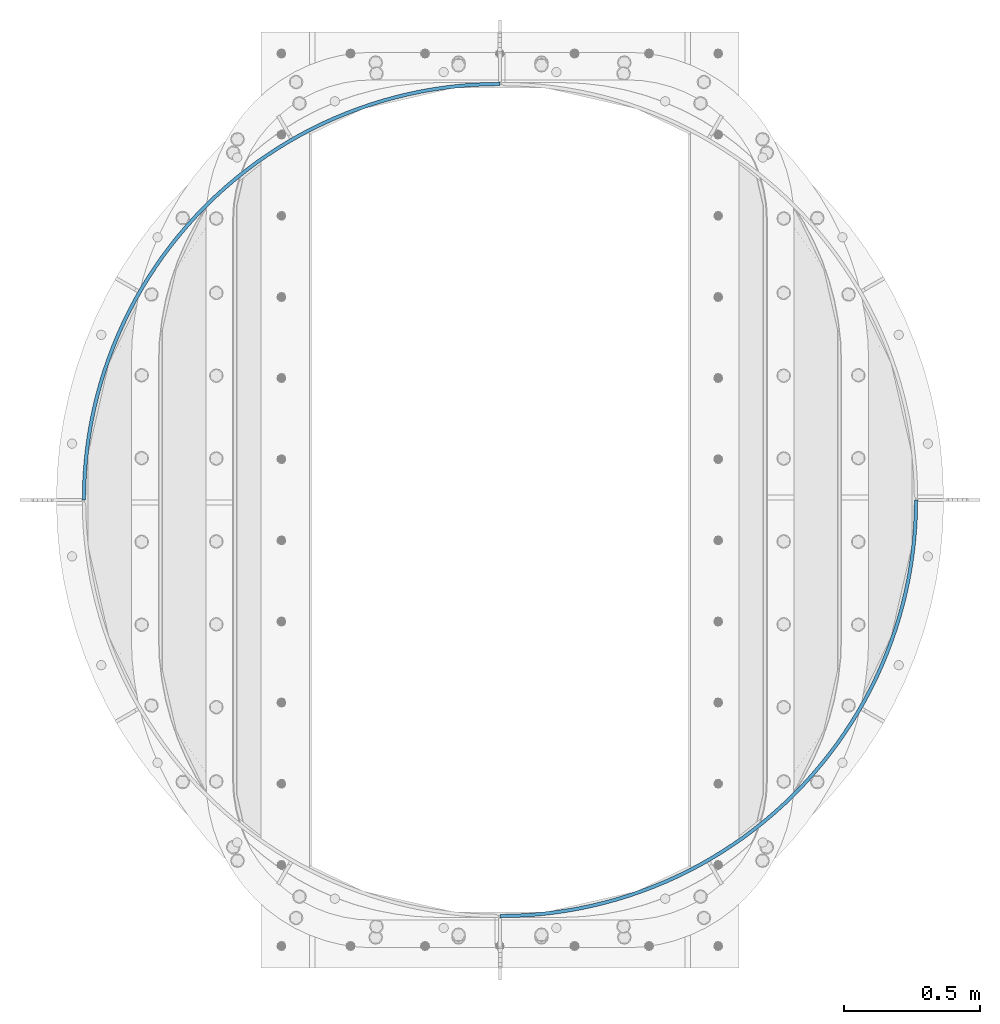
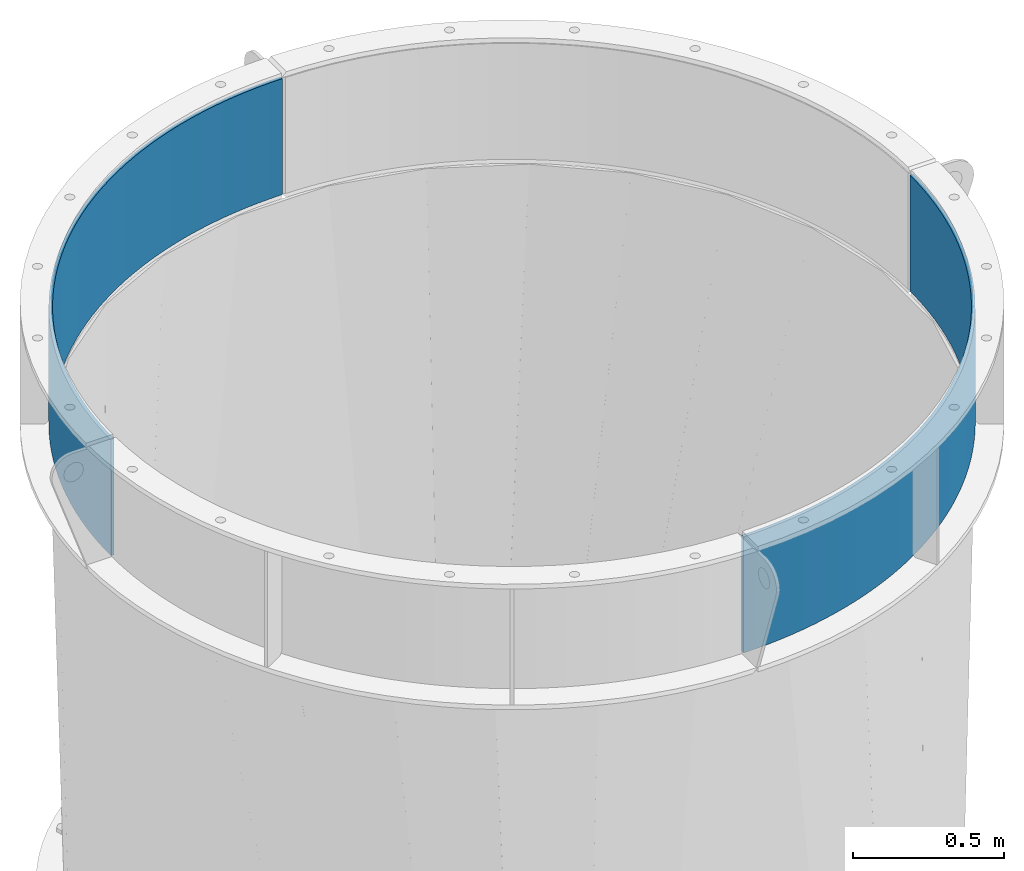
# One storey, part 8 of 15: 2 beams, 1 element without a shape of its own.
"""IFC2X3 building model written with IfcOpenShell, lengths in millimetres."""

import ifcopenshell
import ifcopenshell.guid

model = None  # the IFC model being written
_history = None  # IfcOwnerHistory: only IFC2X3 demands one
_inside = {}  # id of a spatial element -> (the spatial element, [elements in it])
_under = {}  # id of a project, library or spatial element -> (it, [spatial elements below it])
_declared = {}  # id of a project -> (the project, [libraries it declares])
_typed = {}  # id of a type object -> (the type object, [elements of that type])
_made_of = {}  # id of a material, layer set ... -> (it, [elements and type objects made of it])


def new_model(schema):
    """Start an empty IFC model of exactly this schema.

    Asked for "IFC4X3", IfcOpenShell would pick the latest addendum, in which some entities
    have other attributes; the version numbers below select the first issue.
    IFC2X3 requires an IfcOwnerHistory on every rooted entity: one is made here for all.
    """
    global model, _history
    if schema == "IFC4X3":
        model = ifcopenshell.file(schema_version=(4, 3, 0, 0))
    else:
        model = ifcopenshell.file(schema=schema)
    _inside.clear()
    _under.clear()
    _declared.clear()
    _typed.clear()
    _made_of.clear()
    _history = None
    if model.schema == "IFC2X3":
        org = make("IfcOrganization", Name="unknown")
        user = make(
            "IfcPersonAndOrganization",
            ThePerson=make("IfcPerson", FamilyName="unknown"),
            TheOrganization=org,
        )
        app = make(
            "IfcApplication",
            ApplicationDeveloper=org,
            Version="unknown",
            ApplicationFullName="unknown",
            ApplicationIdentifier="unknown",
        )
        _history = make(
            "IfcOwnerHistory",
            OwningUser=user,
            OwningApplication=app,
            ChangeAction="ADDED",
            CreationDate=0,
        )
    return model


def make(cls, **values):
    """One entity of the class cls with the attributes given. An attribute that is None is left unset."""
    return model.create_entity(
        cls, **{name: value for name, value in values.items() if value is not None}
    )


def rooted(cls, **values):
    """An entity with a GlobalId (a new one), such as an element, a storey or a relation."""
    return make(cls, GlobalId=ifcopenshell.guid.new(), OwnerHistory=_history, **values)


def si_unit(unit_type, name, prefix=None):
    """IfcSIUnit, for example si_unit("LENGTHUNIT", "METRE", prefix="MILLI")."""
    return make("IfcSIUnit", UnitType=unit_type, Prefix=prefix, Name=name)


def assignment(units):
    """IfcUnitAssignment: the units of a project."""
    return None if units is None else make("IfcUnitAssignment", Units=units)


def point(xyz):
    """IfcCartesianPoint."""
    return None if xyz is None else make("IfcCartesianPoint", Coordinates=xyz)


def direction(xyz):
    """IfcDirection."""
    return None if xyz is None else make("IfcDirection", DirectionRatios=xyz)


def frame(location, z_axis=None, x_axis=None):
    """IfcAxis2Placement3D, a coordinate frame: its origin and axes. An axis left out is left unset."""
    return make(
        "IfcAxis2Placement3D",
        Location=point(location),
        Axis=direction(z_axis),
        RefDirection=direction(x_axis),
    )


def origin_with_axes():
    """The frame at (0, 0, 0) with the z axis (0, 0, 1) and the x axis (1, 0, 0) written out."""
    return frame((0.0, 0.0, 0.0), z_axis=(0.0, 0.0, 1.0), x_axis=(1.0, 0.0, 0.0))


def place(relative_to, where):
    """IfcLocalPlacement: puts the frame where relative to a parent placement (None: the world)."""
    return make(
        "IfcLocalPlacement", PlacementRelTo=relative_to, RelativePlacement=where
    )


def context(
    kind, dimensions, precision=None, world=None, true_north=None, identifier=None
):
    """IfcGeometricRepresentationContext, for example the 3D "Model" context."""
    return make(
        "IfcGeometricRepresentationContext",
        ContextIdentifier=identifier,
        ContextType=kind,
        CoordinateSpaceDimension=dimensions,
        Precision=precision,
        WorldCoordinateSystem=world,
        TrueNorth=true_north,
    )


def subcontext(parent, identifier, kind, view, scale=None):
    """IfcGeometricRepresentationSubContext, for example "Body" below "Model"."""
    return make(
        "IfcGeometricRepresentationSubContext",
        ContextIdentifier=identifier,
        ContextType=kind,
        ParentContext=parent,
        TargetScale=scale,
        TargetView=view,
    )


def project(units=None, contexts=None):
    """IfcProject with its units and contexts."""
    return rooted(
        "IfcProject",
        Name="project",
        RepresentationContexts=contexts,
        UnitsInContext=assignment(units),
    )


def spatial(cls, under=None, at=None, **own):
    """A site, building, storey or space (cls), placed at a placement, below another one or the project."""
    s = rooted(cls, ObjectPlacement=at, **own)
    if under is not None:
        _under.setdefault(under.id(), (under, []))[1].append(s)
    return s


def faces_of(points, faces, orient=None, outer=None):
    """IfcFace entities. A face is a list of loops; a loop is a list of indices into points, from 0.

    orient and outer hold one flag for each loop. By default every Orientation is true, the
    first loop of a face is its IfcFaceOuterBound and the others are IfcFaceBound.
    """
    made = []
    for i, loops in enumerate(faces):
        bounds = []
        for j, loop in enumerate(loops):
            is_outer = j == 0 if outer is None else outer[i][j]
            bounds.append(
                make(
                    "IfcFaceOuterBound" if is_outer else "IfcFaceBound",
                    Bound=make("IfcPolyLoop", Polygon=[points[k] for k in loop]),
                    Orientation=True if orient is None else orient[i][j],
                )
            )
        made.append(make("IfcFace", Bounds=bounds))
    return made


def faceted_brep(points, faces, orient=None, outer=None, voids=None):
    """IfcFacetedBrep: a solid bounded by flat faces; with voids (closed shells), ...WithVoids."""
    shared = [point(p) for p in points]
    hull = make("IfcClosedShell", CfsFaces=faces_of(shared, faces, orient, outer))
    if voids is None:
        return make("IfcFacetedBrep", Outer=hull)
    return make(
        "IfcFacetedBrepWithVoids",
        Outer=hull,
        Voids=[
            make(cls, CfsFaces=faces_of(shared, fs, o, b)) for cls, fs, o, b in voids
        ],
    )


def shape(context_of_items, identifier, shape_type, items):
    """IfcShapeRepresentation: the items that make up one representation, for example the "Body"."""
    return make(
        "IfcShapeRepresentation",
        ContextOfItems=context_of_items,
        RepresentationIdentifier=identifier,
        RepresentationType=shape_type,
        Items=items,
    )


def material(Name=None, Category=None):
    """IfcMaterial."""
    return make("IfcMaterial", Name=Name, Category=Category)


def made_of(thing, what):
    """Note that an element or type object is made of a material, layer set ...; save() writes the relation."""
    if what is not None:
        _made_of.setdefault(what.id(), (what, []))[1].append(thing)
    return thing


def type_object(cls, material=None, **own):
    """A type object (cls), such as IfcWallType, which elements share."""
    return made_of(rooted(cls, **own), material)


def element(
    cls,
    number,
    at=None,
    inside=None,
    cuts=None,
    type_object=None,
    material=None,
    context=None,
    identifier="Body",
    shape_type=None,
    held_by="IfcProductDefinitionShape",
    body=None,
    shapes=None,
    **own,
):
    """One element of the class cls, such as IfcWall. Its Tag is "e" and its number.

    at: its placement. inside: the storey or other place that contains it. cuts: it is an
    opening in that element (IfcRelVoidsElement). A single representation is given by context,
    identifier, shape_type and body (its items); several are given by shapes. held_by: the class
    of the entity that holds the representations. save() writes the other relations.
    """
    e = rooted(cls, Tag="e%d" % number, ObjectPlacement=at, **own)
    if body is not None:
        shapes = [shape(context, identifier, shape_type, body)]
    if shapes is not None:
        e.Representation = make(held_by, Representations=shapes)
    if inside is not None:
        _inside.setdefault(inside.id(), (inside, []))[1].append(e)
    if cuts is not None:
        rooted(
            "IfcRelVoidsElement", RelatingBuildingElement=cuts, RelatedOpeningElement=e
        )
    if type_object is not None:
        _typed.setdefault(type_object.id(), (type_object, []))[1].append(e)
    return made_of(e, material)


def aggregate(whole, parts):
    """IfcRelAggregates: a whole, such as a stair, and the parts it consists of."""
    return rooted("IfcRelAggregates", RelatingObject=whole, RelatedObjects=parts)


def save(model, path):
    """Write the relations noted so far, then the file.

    IfcRelAggregates (storeys below a building ...), IfcRelContainedInSpatialStructure (elements
    in a storey), IfcRelDefinesByType, IfcRelAssociatesMaterial and IfcRelDeclares: one each for
    every whole, place, type object, material and project.
    """
    for whole, parts in _under.values():
        aggregate(whole, parts)
    for where, things in _inside.values():
        rooted(
            "IfcRelContainedInSpatialStructure",
            RelatedElements=things,
            RelatingStructure=where,
        )
    for kind, things in _typed.values():
        rooted("IfcRelDefinesByType", RelatedObjects=things, RelatingType=kind)
    for what, things in _made_of.values():
        rooted("IfcRelAssociatesMaterial", RelatedObjects=things, RelatingMaterial=what)
    for by, libraries in _declared.values():
        rooted("IfcRelDeclares", RelatingContext=by, RelatedDefinitions=libraries)
    model.write(path)


model = new_model("IFC2X3")

# Units and contexts
model_context = context("Model", 3, precision=1e-05, world=origin_with_axes())
body_context = subcontext(model_context, "Body", "Model", "MODEL_VIEW")
ifc_project = project(units=[si_unit("LENGTHUNIT", "METRE", prefix="MILLI"), si_unit("AREAUNIT", "SQUARE_METRE"), si_unit("VOLUMEUNIT", "CUBIC_METRE"), si_unit("MASSUNIT", "GRAM", prefix="KILO"), si_unit("TIMEUNIT", "SECOND"), si_unit("PLANEANGLEUNIT", "RADIAN"), si_unit("SOLIDANGLEUNIT", "STERADIAN"), si_unit("THERMODYNAMICTEMPERATUREUNIT", "DEGREE_CELSIUS"), si_unit("LUMINOUSINTENSITYUNIT", "LUMEN")], contexts=[model_context])

# Site, building, storey
site_placement = place(None, origin_with_axes())
site = spatial("IfcSite", under=ifc_project, at=site_placement, CompositionType="ELEMENT")
building_placement = place(site_placement, origin_with_axes())
building = spatial("IfcBuilding", under=site, at=building_placement, Name="Undefined", CompositionType="ELEMENT")
storey_placement = place(building_placement, origin_with_axes())
storey = spatial("IfcBuildingStorey", under=building, at=storey_placement, Name="Undefined", CompositionType="ELEMENT", Elevation=0.0)

# Assembly, beams
assembly_placement = place(storey_placement, origin_with_axes())
assembly = element("IfcElementAssembly", 1, at=assembly_placement, inside=storey, Name="TRANSITION", AssemblyPlace="NOTDEFINED", PredefinedType="RIGID_FRAME")
ifc_material = material(Name="STEEL/A36")
beam_type = type_object("IfcBeamType", PredefinedType="NOTDEFINED")
beam_1_placement = place(assembly_placement, frame((-650.875000000268, 1720.85000000022, 6518.28), z_axis=(0.0, 0.0, 1.0), x_axis=(0.707106781186548, 0.707106781186547, 0.0)))
beam_1 = element("IfcBeam", 2, at=beam_1_placement, type_object=beam_type, material=ifc_material, Name="PLATE", context=body_context, shape_type="Brep", body=[
    faceted_brep([(-4.49012806053565, 4.49012806053361, -234.95), (-4.49012806053565, 4.49012806053361, 234.95), (30.1773249082131, 38.0852271696592, 234.95), (30.1773249082131, 38.0852271696592, -234.95), (4.49012806053531, -4.49012806053383, 234.95), (4.49012806053531, -4.49012806053383, -234.95), (38.8710731535093, 28.8273256014088, -234.95), (38.8710731535093, 28.8273256014088, 234.95), (65.8829191459708, 70.5748181123124, 234.95), (65.8829191459708, 70.5748181123124, -234.95), (74.2815798355832, 61.0484075280069, -234.95), (74.2815798355832, 61.0484075280069, 234.95), (102.591417542014, 101.92683758475, 234.95), (102.591417542014, 101.92683758475, -234.95), (110.686702211824, 92.1413194014985, -234.95), (110.686702211824, 92.1413194014985, 234.95), (140.266593240295, 132.110344928926, 234.95), (140.266593240295, 132.110344928926, -234.95), (148.05051282169, 122.075376271756, -234.95), (148.05051282169, 122.075376271756, 234.95), (178.871265390981, 161.095552667193, 234.95), (178.871265390981, 161.095552667193, -234.95), (186.336138095097, 150.821036838632, -234.95), (186.336138095097, 150.821036838632, 234.95), (218.367335843456, 188.853855898938, 234.95), (218.367335843456, 188.853855898938, -234.95), (225.50579474218, 178.349932605652, -234.95), (225.50579474218, 178.349932605652, 234.95), (258.715826744602, 215.357860530173, 234.95), (258.715826744602, 215.357860530173, -234.95), (265.520827040837, 204.634895876298, -234.95), (265.520827040837, 204.634895876298, 234.95), (299.876919005232, 240.581410308193, 234.95), (299.876919005232, 240.581410308193, -234.95), (306.341744985264, 229.649986565244, -234.95), (306.341744985264, 229.649986565244, 234.95), (341.809991596724, 264.499612634644, 234.95), (341.809991596724, 264.499612634644, -234.95), (347.928263257818, 253.370517798088, -234.95), (347.928263257818, 253.370517798088, 234.95), (384.473661639071, 287.088863131509, 234.95), (384.473661639071, 287.088863131509, -234.95), (390.239340985765, 275.773080274318, -234.95), (390.239340985765, 275.773080274318, 234.95), (427.825825240789, 308.326868935782, 234.95), (427.825825240789, 308.326868935782, -234.95), (433.233222243668, 296.835565369465, -234.95), (433.233222243668, 296.835565369465, 234.95), (471.823699050373, 328.192670699828, 234.95), (471.823699050373, 328.192670699828, -234.95), (476.867477261437, 316.537186953643, -234.95), (476.867477261437, 316.537186953643, 234.95), (516.423862478301, 346.666663275734, 234.95), (516.423862478301, 346.666663275734, -234.95), (521.099044297397, 334.858501904954, -234.95), (521.099044297397, 334.858501904954, 234.95), (561.582300547911, 363.73061506322, 234.95), (561.582300547911, 363.73061506322, -234.95), (565.884272135028, 351.781429297502, -234.95), (565.884272135028, 351.781429297502, 234.95), (607.254447332874, 379.367686002027, 234.95), (607.254447332874, 379.367686002027, -234.95), (611.178963161437, 367.289268245079, -234.95), (611.178963161437, 367.289268245079, 234.95), (653.395229938378, 393.562444191024, 234.95), (653.395229938378, 393.562444191024, -234.95), (656.938416985078, 381.366714382928, -234.95), (656.938416985078, 381.366714382928, 234.95), (699.959112982635, 406.300881117635, 234.95), (699.959112982635, 406.300881117635, -234.95), (703.11747454963, 393.999874971302, -234.95), (703.11747454963, 393.999874971302, 234.95), (746.900143534807, 417.570425482542, 234.95), (746.900143534807, 417.570425482542, -234.95), (749.670562700545, 405.17628260592, -234.95), (749.670562700545, 405.17628260592, 234.95), (794.171996464998, 427.359955606045, 234.95), (794.171996464998, 427.359955606045, -234.95), (796.551739160238, 414.884907521791, -234.95), (796.551739160238, 414.884907521791, 234.95), (841.728020161566, 435.659810403817, 234.95), (841.728020161566, 435.659810403817, -234.95), (843.714737867578, 423.116168478259, -234.95), (843.714737867578, 423.116168478259, 234.95), (889.52128257063, 442.461798921226, 234.95), (889.52128257063, 442.461798921226, -234.95), (891.113014636898, 429.861942214533, -234.95), (891.113014636898, 429.861942214533, 234.95), (937.504617512343, 447.759208416819, 234.95), (937.504617512343, 447.759208416819, -234.95), (938.699793091489, 435.115571466361, -234.95), (938.699793091489, 435.115571466361, 234.95), (985.630671228216, 451.546810986989, 234.95), (985.630671228216, 451.546810986989, -234.95), (986.42811082624, 438.871871535951, -234.95), (986.42811082624, 438.871871535951, 234.95), (1033.85194911356, 453.820868725281, 234.95), (1033.85194911356, 453.820868725281, -234.95), (1034.25086575385, 441.127135408636, -234.95), (1034.25086575385, 441.127135408636, 234.95), (1082.12086258893, 454.579137411258, 234.95), (1082.12086258893, 454.579137411258, -234.95), (1082.12086258893, 441.879137411258, -234.95), (1082.12086258893, 441.879137411258, 234.95), (1130.3897760643, 453.820868725272, 234.95), (1130.3897760643, 453.820868725272, -234.95), (1129.99085942401, 441.127135408629, -234.95), (1129.99085942401, 441.127135408629, 234.95), (1178.61105394964, 451.546810986973, 234.95), (1178.61105394964, 451.546810986973, -234.95), (1177.81361435162, 438.871871535935, -234.95), (1177.81361435162, 438.871871535935, 234.95), (1226.73710766552, 447.759208416796, 234.95), (1226.73710766552, 447.759208416796, -234.95), (1225.54193208637, 435.115571466338, -234.95), (1225.54193208637, 435.115571466338, 234.95), (1274.72044260723, 442.461798921194, 234.95), (1274.72044260723, 442.461798921194, -234.95), (1273.12871054096, 429.861942214502, -234.95), (1273.12871054096, 429.861942214502, 234.95), (1322.51370501629, 435.659810403778, 234.95), (1322.51370501629, 435.659810403778, -234.95), (1320.52698731028, 423.116168478221, -234.95), (1320.52698731028, 423.116168478221, 234.95), (1370.06972871286, 427.359955605998, 234.95), (1370.06972871286, 427.359955605998, -234.95), (1367.68998601762, 414.884907521745, -234.95), (1367.68998601762, 414.884907521745, 234.95), (1417.34158164306, 417.570425482488, 234.95), (1417.34158164306, 417.570425482488, -234.95), (1414.57116247732, 405.176282605867, -234.95), (1414.57116247732, 405.176282605867, 234.95), (1464.28261219523, 406.300881117574, 234.95), (1464.28261219523, 406.300881117574, -234.95), (1461.12425062824, 393.999874971241, -234.95), (1461.12425062824, 393.999874971241, 234.95), (1510.84649523949, 393.562444190955, 234.95), (1510.84649523949, 393.562444190955, -234.95), (1507.30330819279, 381.36671438286, -234.95), (1507.30330819279, 381.36671438286, 234.95), (1556.98727784499, 379.36768600195, 234.95), (1556.98727784499, 379.36768600195, -234.95), (1553.06276201643, 367.289268245003, -234.95), (1553.06276201643, 367.289268245003, 234.95), (1602.65942462996, 363.730615063135, 234.95), (1602.65942462996, 363.730615063135, -234.95), (1598.35745304285, 351.781429297419, -234.95), (1598.35745304285, 351.781429297419, 234.95), (1647.81786269957, 346.666663275642, 234.95), (1647.81786269957, 346.666663275642, -234.95), (1643.14268088048, 334.858501904863, -234.95), (1643.14268088048, 334.858501904863, 234.95), (1692.4180261275, 328.192670699729, 234.95), (1692.4180261275, 328.192670699729, -234.95), (1687.37424791644, 316.537186953544, -234.95), (1687.37424791644, 316.537186953544, 234.95), (1736.41589993709, 308.326868935676, 234.95), (1736.41589993709, 308.326868935676, -234.95), (1731.00850293421, 296.835565369359, -234.95), (1731.00850293421, 296.835565369359, 234.95), (1779.76806353881, 287.088863131397, 234.95), (1779.76806353881, 287.088863131397, -234.95), (1774.00238419212, 275.773080274206, -234.95), (1774.00238419212, 275.773080274206, 234.95), (1822.43173358116, 264.499612634525, 234.95), (1822.43173358116, 264.499612634525, -234.95), (1816.31346192007, 253.370517797969, -234.95), (1816.31346192007, 253.370517797969, 234.95), (1864.36480617266, 240.581410308067, 234.95), (1864.36480617266, 240.581410308067, -234.95), (1857.89998019263, 229.649986565118, -234.95), (1857.89998019263, 229.649986565118, 234.95), (1905.52589843329, 215.357860530039, 234.95), (1905.52589843329, 215.357860530039, -234.95), (1898.72089813706, 204.634895876166, -234.95), (1898.72089813706, 204.634895876166, 234.95), (1945.87438933444, 188.853855898798, 234.95), (1945.87438933444, 188.853855898798, -234.95), (1938.73593043572, 178.349932605514, -234.95), (1938.73593043572, 178.349932605514, 234.95), (1985.37045978692, 161.095552667047, 234.95), (1985.37045978692, 161.095552667047, -234.95), (1977.90558708281, 150.821036838488, -234.95), (1977.90558708281, 150.821036838488, 234.95), (2023.97513193761, 132.110344928774, 234.95), (2023.97513193761, 132.110344928774, -234.95), (2016.19121235622, 122.075376271606, -234.95), (2016.19121235622, 122.075376271606, 234.95), (2061.6503076359, 101.926837584591, 234.95), (2061.6503076359, 101.926837584591, -234.95), (2053.55502296609, 92.1413194013419, -234.95), (2053.55502296609, 92.1413194013419, 234.95), (2098.35880603195, 70.5748181121483, 234.95), (2098.35880603195, 70.5748181121483, -234.95), (2089.96014534234, 61.0484075278443, -234.95), (2089.96014534234, 61.0484075278443, 234.95), (2134.06440026971, 38.0852271694891, 234.95), (2134.06440026971, 38.0852271694891, -234.95), (2125.37065202442, 28.8273256012403, -234.95), (2125.37065202442, 28.8273256012403, 234.95), (2168.73185323846, 4.4901280603583, 234.95), (2168.73185323846, 4.4901280603583, -234.95), (2159.7515971174, -4.49012806070755, 234.95), (2159.7515971174, -4.49012806070755, -234.95)], [[[0, 1, 2, 3]], [[4, 5, 6, 7]], [[5, 4, 1, 0]], [[3, 2, 8, 9]], [[7, 6, 10, 11]], [[9, 8, 12, 13]], [[11, 10, 14, 15]], [[13, 12, 16, 17]], [[15, 14, 18, 19]], [[17, 16, 20, 21]], [[19, 18, 22, 23]], [[21, 20, 24, 25]], [[23, 22, 26, 27]], [[25, 24, 28, 29]], [[27, 26, 30, 31]], [[29, 28, 32, 33]], [[31, 30, 34, 35]], [[33, 32, 36, 37]], [[35, 34, 38, 39]], [[37, 36, 40, 41]], [[39, 38, 42, 43]], [[41, 40, 44, 45]], [[43, 42, 46, 47]], [[45, 44, 48, 49]], [[47, 46, 50, 51]], [[49, 48, 52, 53]], [[51, 50, 54, 55]], [[53, 52, 56, 57]], [[55, 54, 58, 59]], [[57, 56, 60, 61]], [[59, 58, 62, 63]], [[61, 60, 64, 65]], [[63, 62, 66, 67]], [[65, 64, 68, 69]], [[67, 66, 70, 71]], [[69, 68, 72, 73]], [[71, 70, 74, 75]], [[73, 72, 76, 77]], [[75, 74, 78, 79]], [[77, 76, 80, 81]], [[79, 78, 82, 83]], [[81, 80, 84, 85]], [[83, 82, 86, 87]], [[85, 84, 88, 89]], [[87, 86, 90, 91]], [[89, 88, 92, 93]], [[91, 90, 94, 95]], [[93, 92, 96, 97]], [[95, 94, 98, 99]], [[97, 96, 100, 101]], [[99, 98, 102, 103]], [[101, 100, 104, 105]], [[103, 102, 106, 107]], [[105, 104, 108, 109]], [[107, 106, 110, 111]], [[109, 108, 112, 113]], [[111, 110, 114, 115]], [[113, 112, 116, 117]], [[115, 114, 118, 119]], [[117, 116, 120, 121]], [[119, 118, 122, 123]], [[121, 120, 124, 125]], [[123, 122, 126, 127]], [[125, 124, 128, 129]], [[127, 126, 130, 131]], [[129, 128, 132, 133]], [[131, 130, 134, 135]], [[133, 132, 136, 137]], [[135, 134, 138, 139]], [[137, 136, 140, 141]], [[139, 138, 142, 143]], [[141, 140, 144, 145]], [[143, 142, 146, 147]], [[145, 144, 148, 149]], [[147, 146, 150, 151]], [[149, 148, 152, 153]], [[151, 150, 154, 155]], [[153, 152, 156, 157]], [[155, 154, 158, 159]], [[157, 156, 160, 161]], [[159, 158, 162, 163]], [[161, 160, 164, 165]], [[163, 162, 166, 167]], [[165, 164, 168, 169]], [[167, 166, 170, 171]], [[169, 168, 172, 173]], [[171, 170, 174, 175]], [[173, 172, 176, 177]], [[175, 174, 178, 179]], [[177, 176, 180, 181]], [[179, 178, 182, 183]], [[181, 180, 184, 185]], [[183, 182, 186, 187]], [[185, 184, 188, 189]], [[187, 186, 190, 191]], [[189, 188, 192, 193]], [[191, 190, 194, 195]], [[193, 192, 196, 197]], [[195, 194, 198, 199]], [[197, 196, 200, 201]], [[196, 192, 188, 184, 180, 176, 172, 168, 164, 160, 156, 152, 148, 144, 140, 136, 132, 128, 124, 120, 116, 112, 108, 104, 100, 96, 92, 88, 84, 80, 76, 72, 68, 64, 60, 56, 52, 48, 44, 40, 36, 32, 28, 24, 20, 16, 12, 8, 2, 1, 4, 7, 11, 15, 19, 23, 27, 31, 35, 39, 43, 47, 51, 55, 59, 63, 67, 71, 75, 79, 83, 87, 91, 95, 99, 103, 107, 111, 115, 119, 123, 127, 131, 135, 139, 143, 147, 151, 155, 159, 163, 167, 171, 175, 179, 183, 187, 191, 195, 199, 202, 200]], [[199, 198, 203, 202]], [[198, 194, 190, 186, 182, 178, 174, 170, 166, 162, 158, 154, 150, 146, 142, 138, 134, 130, 126, 122, 118, 114, 110, 106, 102, 98, 94, 90, 86, 82, 78, 74, 70, 66, 62, 58, 54, 50, 46, 42, 38, 34, 30, 26, 22, 18, 14, 10, 6, 5, 0, 3, 9, 13, 17, 21, 25, 29, 33, 37, 41, 45, 49, 53, 57, 61, 65, 69, 73, 77, 81, 85, 89, 93, 97, 101, 105, 109, 113, 117, 121, 125, 129, 133, 137, 141, 145, 149, 153, 157, 161, 165, 169, 173, 177, 181, 185, 189, 193, 197, 201, 203]], [[202, 203, 201, 200]]]),
])
beam_2_placement = place(assembly_placement, frame((2409.82500000027, 1720.84999999978, 6518.28), z_axis=(0.0, 0.0, 1.0), x_axis=(-0.707106781186548, -0.707106781186548, 0.0)))
beam_2 = element("IfcBeam", 3, at=beam_2_placement, type_object=beam_type, material=ifc_material, Name="PLATE", context=body_context, shape_type="Brep", body=[
    faceted_brep([(-4.49012806053565, 4.49012806053361, -234.95), (-4.49012806053565, 4.49012806053361, 234.95), (30.1773249082131, 38.0852271696592, 234.95), (30.1773249082131, 38.0852271696592, -234.95), (4.49012806053531, -4.49012806053383, 234.95), (4.49012806053531, -4.49012806053383, -234.95), (38.8710731535093, 28.8273256014088, -234.95), (38.8710731535093, 28.8273256014088, 234.95), (65.8829191459708, 70.5748181123124, 234.95), (65.8829191459708, 70.5748181123124, -234.95), (74.2815798355832, 61.0484075280069, -234.95), (74.2815798355832, 61.0484075280069, 234.95), (102.591417542014, 101.92683758475, 234.95), (102.591417542014, 101.92683758475, -234.95), (110.686702211824, 92.1413194014985, -234.95), (110.686702211824, 92.1413194014985, 234.95), (140.266593240295, 132.110344928926, 234.95), (140.266593240295, 132.110344928926, -234.95), (148.05051282169, 122.075376271756, -234.95), (148.05051282169, 122.075376271756, 234.95), (178.871265390981, 161.095552667193, 234.95), (178.871265390981, 161.095552667193, -234.95), (186.336138095097, 150.821036838632, -234.95), (186.336138095097, 150.821036838632, 234.95), (218.367335843456, 188.853855898938, 234.95), (218.367335843456, 188.853855898938, -234.95), (225.50579474218, 178.349932605652, -234.95), (225.50579474218, 178.349932605652, 234.95), (258.715826744602, 215.357860530173, 234.95), (258.715826744602, 215.357860530173, -234.95), (265.520827040837, 204.634895876298, -234.95), (265.520827040837, 204.634895876298, 234.95), (299.876919005232, 240.581410308193, 234.95), (299.876919005232, 240.581410308193, -234.95), (306.341744985264, 229.649986565244, -234.95), (306.341744985264, 229.649986565244, 234.95), (341.809991596724, 264.499612634644, 234.95), (341.809991596724, 264.499612634644, -234.95), (347.928263257818, 253.370517798088, -234.95), (347.928263257818, 253.370517798088, 234.95), (384.473661639071, 287.088863131509, 234.95), (384.473661639071, 287.088863131509, -234.95), (390.239340985765, 275.773080274318, -234.95), (390.239340985765, 275.773080274318, 234.95), (427.825825240789, 308.326868935782, 234.95), (427.825825240789, 308.326868935782, -234.95), (433.233222243668, 296.835565369465, -234.95), (433.233222243668, 296.835565369465, 234.95), (471.823699050373, 328.192670699828, 234.95), (471.823699050373, 328.192670699828, -234.95), (476.867477261437, 316.537186953643, -234.95), (476.867477261437, 316.537186953643, 234.95), (516.423862478301, 346.666663275734, 234.95), (516.423862478301, 346.666663275734, -234.95), (521.099044297397, 334.858501904954, -234.95), (521.099044297397, 334.858501904954, 234.95), (561.582300547911, 363.73061506322, 234.95), (561.582300547911, 363.73061506322, -234.95), (565.884272135028, 351.781429297502, -234.95), (565.884272135028, 351.781429297502, 234.95), (607.254447332874, 379.367686002027, 234.95), (607.254447332874, 379.367686002027, -234.95), (611.178963161437, 367.289268245079, -234.95), (611.178963161437, 367.289268245079, 234.95), (653.395229938378, 393.562444191024, 234.95), (653.395229938378, 393.562444191024, -234.95), (656.938416985078, 381.366714382928, -234.95), (656.938416985078, 381.366714382928, 234.95), (699.959112982635, 406.300881117635, 234.95), (699.959112982635, 406.300881117635, -234.95), (703.11747454963, 393.999874971302, -234.95), (703.11747454963, 393.999874971302, 234.95), (746.900143534807, 417.570425482542, 234.95), (746.900143534807, 417.570425482542, -234.95), (749.670562700545, 405.17628260592, -234.95), (749.670562700545, 405.17628260592, 234.95), (794.171996464998, 427.359955606045, 234.95), (794.171996464998, 427.359955606045, -234.95), (796.551739160238, 414.884907521791, -234.95), (796.551739160238, 414.884907521791, 234.95), (841.728020161566, 435.659810403817, 234.95), (841.728020161566, 435.659810403817, -234.95), (843.714737867578, 423.116168478259, -234.95), (843.714737867578, 423.116168478259, 234.95), (889.52128257063, 442.461798921226, 234.95), (889.52128257063, 442.461798921226, -234.95), (891.113014636898, 429.861942214533, -234.95), (891.113014636898, 429.861942214533, 234.95), (937.504617512343, 447.759208416819, 234.95), (937.504617512343, 447.759208416819, -234.95), (938.699793091489, 435.115571466361, -234.95), (938.699793091489, 435.115571466361, 234.95), (985.630671228216, 451.546810986989, 234.95), (985.630671228216, 451.546810986989, -234.95), (986.42811082624, 438.871871535951, -234.95), (986.42811082624, 438.871871535951, 234.95), (1033.85194911356, 453.820868725281, 234.95), (1033.85194911356, 453.820868725281, -234.95), (1034.25086575385, 441.127135408636, -234.95), (1034.25086575385, 441.127135408636, 234.95), (1082.12086258893, 454.579137411258, 234.95), (1082.12086258893, 454.579137411258, -234.95), (1082.12086258893, 441.879137411258, -234.95), (1082.12086258893, 441.879137411258, 234.95), (1130.3897760643, 453.820868725272, 234.95), (1130.3897760643, 453.820868725272, -234.95), (1129.99085942401, 441.127135408629, -234.95), (1129.99085942401, 441.127135408629, 234.95), (1178.61105394964, 451.546810986973, 234.95), (1178.61105394964, 451.546810986973, -234.95), (1177.81361435162, 438.871871535935, -234.95), (1177.81361435162, 438.871871535935, 234.95), (1226.73710766552, 447.759208416796, 234.95), (1226.73710766552, 447.759208416796, -234.95), (1225.54193208637, 435.115571466338, -234.95), (1225.54193208637, 435.115571466338, 234.95), (1274.72044260723, 442.461798921194, 234.95), (1274.72044260723, 442.461798921194, -234.95), (1273.12871054096, 429.861942214502, -234.95), (1273.12871054096, 429.861942214502, 234.95), (1322.51370501629, 435.659810403778, 234.95), (1322.51370501629, 435.659810403778, -234.95), (1320.52698731028, 423.116168478221, -234.95), (1320.52698731028, 423.116168478221, 234.95), (1370.06972871286, 427.359955605998, 234.95), (1370.06972871286, 427.359955605998, -234.95), (1367.68998601762, 414.884907521745, -234.95), (1367.68998601762, 414.884907521745, 234.95), (1417.34158164306, 417.570425482488, 234.95), (1417.34158164306, 417.570425482488, -234.95), (1414.57116247732, 405.176282605867, -234.95), (1414.57116247732, 405.176282605867, 234.95), (1464.28261219523, 406.300881117574, 234.95), (1464.28261219523, 406.300881117574, -234.95), (1461.12425062824, 393.999874971241, -234.95), (1461.12425062824, 393.999874971241, 234.95), (1510.84649523949, 393.562444190955, 234.95), (1510.84649523949, 393.562444190955, -234.95), (1507.30330819279, 381.36671438286, -234.95), (1507.30330819279, 381.36671438286, 234.95), (1556.98727784499, 379.36768600195, 234.95), (1556.98727784499, 379.36768600195, -234.95), (1553.06276201643, 367.289268245003, -234.95), (1553.06276201643, 367.289268245003, 234.95), (1602.65942462996, 363.730615063135, 234.95), (1602.65942462996, 363.730615063135, -234.95), (1598.35745304285, 351.781429297419, -234.95), (1598.35745304285, 351.781429297419, 234.95), (1647.81786269957, 346.666663275642, 234.95), (1647.81786269957, 346.666663275642, -234.95), (1643.14268088048, 334.858501904863, -234.95), (1643.14268088048, 334.858501904863, 234.95), (1692.4180261275, 328.192670699729, 234.95), (1692.4180261275, 328.192670699729, -234.95), (1687.37424791644, 316.537186953544, -234.95), (1687.37424791644, 316.537186953544, 234.95), (1736.41589993709, 308.326868935676, 234.95), (1736.41589993709, 308.326868935676, -234.95), (1731.00850293421, 296.835565369359, -234.95), (1731.00850293421, 296.835565369359, 234.95), (1779.76806353881, 287.088863131397, 234.95), (1779.76806353881, 287.088863131397, -234.95), (1774.00238419212, 275.773080274206, -234.95), (1774.00238419212, 275.773080274206, 234.95), (1822.43173358116, 264.499612634525, 234.95), (1822.43173358116, 264.499612634525, -234.95), (1816.31346192007, 253.370517797969, -234.95), (1816.31346192007, 253.370517797969, 234.95), (1864.36480617266, 240.581410308067, 234.95), (1864.36480617266, 240.581410308067, -234.95), (1857.89998019263, 229.649986565118, -234.95), (1857.89998019263, 229.649986565118, 234.95), (1905.52589843329, 215.357860530039, 234.95), (1905.52589843329, 215.357860530039, -234.95), (1898.72089813706, 204.634895876166, -234.95), (1898.72089813706, 204.634895876166, 234.95), (1945.87438933444, 188.853855898798, 234.95), (1945.87438933444, 188.853855898798, -234.95), (1938.73593043572, 178.349932605514, -234.95), (1938.73593043572, 178.349932605514, 234.95), (1985.37045978692, 161.095552667047, 234.95), (1985.37045978692, 161.095552667047, -234.95), (1977.90558708281, 150.821036838488, -234.95), (1977.90558708281, 150.821036838488, 234.95), (2023.97513193761, 132.110344928774, 234.95), (2023.97513193761, 132.110344928774, -234.95), (2016.19121235622, 122.075376271606, -234.95), (2016.19121235622, 122.075376271606, 234.95), (2061.6503076359, 101.926837584591, 234.95), (2061.6503076359, 101.926837584591, -234.95), (2053.55502296609, 92.1413194013419, -234.95), (2053.55502296609, 92.1413194013419, 234.95), (2098.35880603195, 70.5748181121483, 234.95), (2098.35880603195, 70.5748181121483, -234.95), (2089.96014534234, 61.0484075278443, -234.95), (2089.96014534234, 61.0484075278443, 234.95), (2134.06440026971, 38.0852271694891, 234.95), (2134.06440026971, 38.0852271694891, -234.95), (2125.37065202442, 28.8273256012403, -234.95), (2125.37065202442, 28.8273256012403, 234.95), (2168.73185323846, 4.4901280603583, 234.95), (2168.73185323846, 4.4901280603583, -234.95), (2159.7515971174, -4.49012806070755, 234.95), (2159.7515971174, -4.49012806070755, -234.95)], [[[0, 1, 2, 3]], [[4, 5, 6, 7]], [[5, 4, 1, 0]], [[3, 2, 8, 9]], [[7, 6, 10, 11]], [[9, 8, 12, 13]], [[11, 10, 14, 15]], [[13, 12, 16, 17]], [[15, 14, 18, 19]], [[17, 16, 20, 21]], [[19, 18, 22, 23]], [[21, 20, 24, 25]], [[23, 22, 26, 27]], [[25, 24, 28, 29]], [[27, 26, 30, 31]], [[29, 28, 32, 33]], [[31, 30, 34, 35]], [[33, 32, 36, 37]], [[35, 34, 38, 39]], [[37, 36, 40, 41]], [[39, 38, 42, 43]], [[41, 40, 44, 45]], [[43, 42, 46, 47]], [[45, 44, 48, 49]], [[47, 46, 50, 51]], [[49, 48, 52, 53]], [[51, 50, 54, 55]], [[53, 52, 56, 57]], [[55, 54, 58, 59]], [[57, 56, 60, 61]], [[59, 58, 62, 63]], [[61, 60, 64, 65]], [[63, 62, 66, 67]], [[65, 64, 68, 69]], [[67, 66, 70, 71]], [[69, 68, 72, 73]], [[71, 70, 74, 75]], [[73, 72, 76, 77]], [[75, 74, 78, 79]], [[77, 76, 80, 81]], [[79, 78, 82, 83]], [[81, 80, 84, 85]], [[83, 82, 86, 87]], [[85, 84, 88, 89]], [[87, 86, 90, 91]], [[89, 88, 92, 93]], [[91, 90, 94, 95]], [[93, 92, 96, 97]], [[95, 94, 98, 99]], [[97, 96, 100, 101]], [[99, 98, 102, 103]], [[101, 100, 104, 105]], [[103, 102, 106, 107]], [[105, 104, 108, 109]], [[107, 106, 110, 111]], [[109, 108, 112, 113]], [[111, 110, 114, 115]], [[113, 112, 116, 117]], [[115, 114, 118, 119]], [[117, 116, 120, 121]], [[119, 118, 122, 123]], [[121, 120, 124, 125]], [[123, 122, 126, 127]], [[125, 124, 128, 129]], [[127, 126, 130, 131]], [[129, 128, 132, 133]], [[131, 130, 134, 135]], [[133, 132, 136, 137]], [[135, 134, 138, 139]], [[137, 136, 140, 141]], [[139, 138, 142, 143]], [[141, 140, 144, 145]], [[143, 142, 146, 147]], [[145, 144, 148, 149]], [[147, 146, 150, 151]], [[149, 148, 152, 153]], [[151, 150, 154, 155]], [[153, 152, 156, 157]], [[155, 154, 158, 159]], [[157, 156, 160, 161]], [[159, 158, 162, 163]], [[161, 160, 164, 165]], [[163, 162, 166, 167]], [[165, 164, 168, 169]], [[167, 166, 170, 171]], [[169, 168, 172, 173]], [[171, 170, 174, 175]], [[173, 172, 176, 177]], [[175, 174, 178, 179]], [[177, 176, 180, 181]], [[179, 178, 182, 183]], [[181, 180, 184, 185]], [[183, 182, 186, 187]], [[185, 184, 188, 189]], [[187, 186, 190, 191]], [[189, 188, 192, 193]], [[191, 190, 194, 195]], [[193, 192, 196, 197]], [[195, 194, 198, 199]], [[197, 196, 200, 201]], [[196, 192, 188, 184, 180, 176, 172, 168, 164, 160, 156, 152, 148, 144, 140, 136, 132, 128, 124, 120, 116, 112, 108, 104, 100, 96, 92, 88, 84, 80, 76, 72, 68, 64, 60, 56, 52, 48, 44, 40, 36, 32, 28, 24, 20, 16, 12, 8, 2, 1, 4, 7, 11, 15, 19, 23, 27, 31, 35, 39, 43, 47, 51, 55, 59, 63, 67, 71, 75, 79, 83, 87, 91, 95, 99, 103, 107, 111, 115, 119, 123, 127, 131, 135, 139, 143, 147, 151, 155, 159, 163, 167, 171, 175, 179, 183, 187, 191, 195, 199, 202, 200]], [[199, 198, 203, 202]], [[198, 194, 190, 186, 182, 178, 174, 170, 166, 162, 158, 154, 150, 146, 142, 138, 134, 130, 126, 122, 118, 114, 110, 106, 102, 98, 94, 90, 86, 82, 78, 74, 70, 66, 62, 58, 54, 50, 46, 42, 38, 34, 30, 26, 22, 18, 14, 10, 6, 5, 0, 3, 9, 13, 17, 21, 25, 29, 33, 37, 41, 45, 49, 53, 57, 61, 65, 69, 73, 77, 81, 85, 89, 93, 97, 101, 105, 109, 113, 117, 121, 125, 129, 133, 137, 141, 145, 149, 153, 157, 161, 165, 169, 173, 177, 181, 185, 189, 193, 197, 201, 203]], [[202, 203, 201, 200]]]),
])
aggregate(assembly, [beam_1, beam_2])

save(model, "model.ifc")
